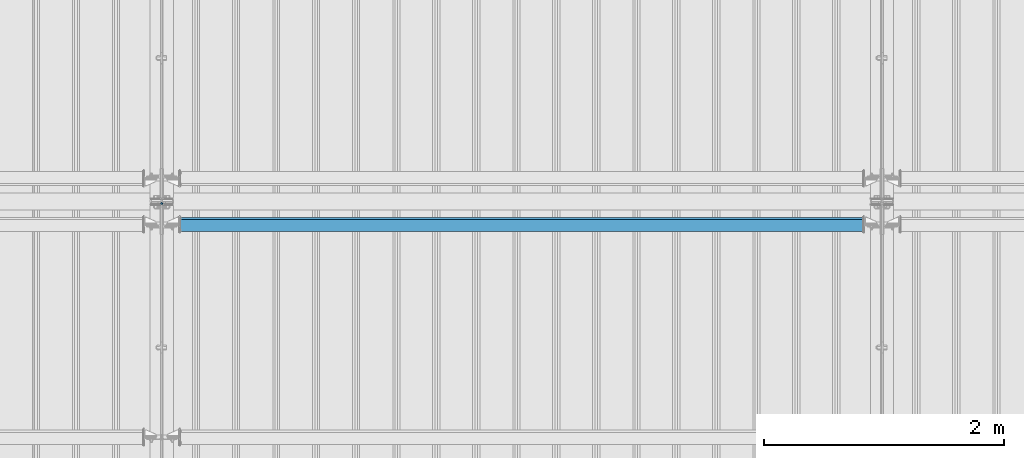
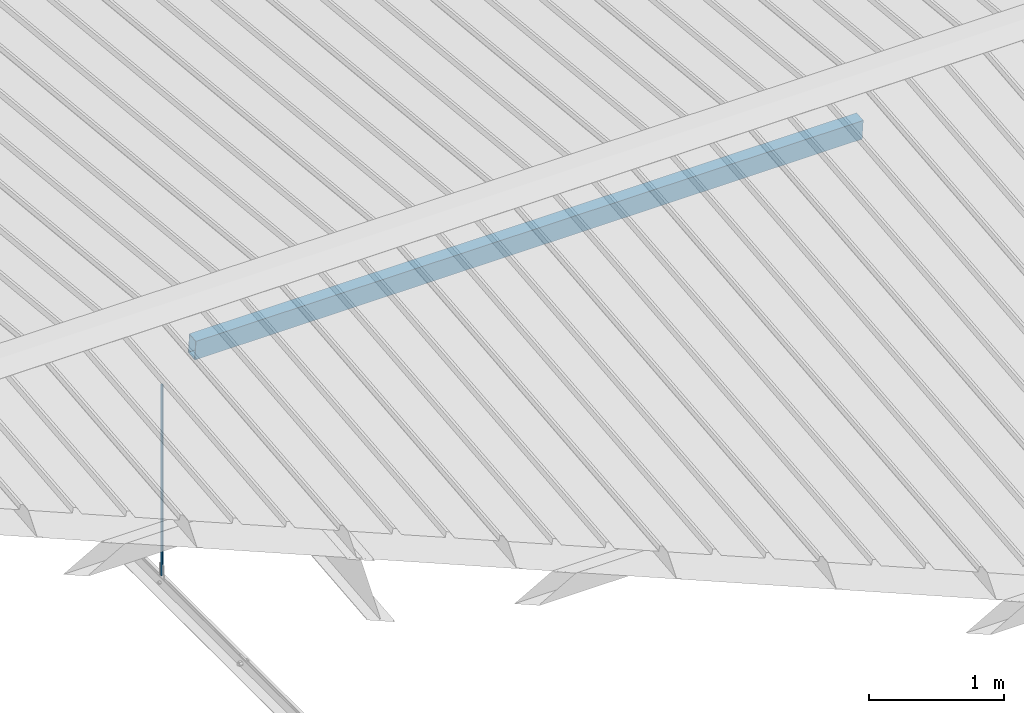
# One storey, part 257 of 709: 2 beams, 2 elements without a shape of their own.
"""IFC4 building model written with IfcOpenShell, lengths in millimetres."""

import ifcopenshell
import ifcopenshell.guid

model = None  # the IFC model being written
_history = None  # IfcOwnerHistory: only IFC2X3 demands one
_inside = {}  # id of a spatial element -> (the spatial element, [elements in it])
_under = {}  # id of a project, library or spatial element -> (it, [spatial elements below it])
_declared = {}  # id of a project -> (the project, [libraries it declares])
_typed = {}  # id of a type object -> (the type object, [elements of that type])
_made_of = {}  # id of a material, layer set ... -> (it, [elements and type objects made of it])


def new_model(schema):
    """Start an empty IFC model of exactly this schema.

    Asked for "IFC4X3", IfcOpenShell would pick the latest addendum, in which some entities
    have other attributes; the version numbers below select the first issue.
    IFC2X3 requires an IfcOwnerHistory on every rooted entity: one is made here for all.
    """
    global model, _history
    if schema == "IFC4X3":
        model = ifcopenshell.file(schema_version=(4, 3, 0, 0))
    else:
        model = ifcopenshell.file(schema=schema)
    _inside.clear()
    _under.clear()
    _declared.clear()
    _typed.clear()
    _made_of.clear()
    _history = None
    if model.schema == "IFC2X3":
        org = make("IfcOrganization", Name="unknown")
        user = make(
            "IfcPersonAndOrganization",
            ThePerson=make("IfcPerson", FamilyName="unknown"),
            TheOrganization=org,
        )
        app = make(
            "IfcApplication",
            ApplicationDeveloper=org,
            Version="unknown",
            ApplicationFullName="unknown",
            ApplicationIdentifier="unknown",
        )
        _history = make(
            "IfcOwnerHistory",
            OwningUser=user,
            OwningApplication=app,
            ChangeAction="ADDED",
            CreationDate=0,
        )
    return model


def make(cls, **values):
    """One entity of the class cls with the attributes given. An attribute that is None is left unset."""
    return model.create_entity(
        cls, **{name: value for name, value in values.items() if value is not None}
    )


def rooted(cls, **values):
    """An entity with a GlobalId (a new one), such as an element, a storey or a relation."""
    return make(cls, GlobalId=ifcopenshell.guid.new(), OwnerHistory=_history, **values)


def si_unit(unit_type, name, prefix=None):
    """IfcSIUnit, for example si_unit("LENGTHUNIT", "METRE", prefix="MILLI")."""
    return make("IfcSIUnit", UnitType=unit_type, Prefix=prefix, Name=name)


def assignment(units):
    """IfcUnitAssignment: the units of a project."""
    return None if units is None else make("IfcUnitAssignment", Units=units)


def point(xyz):
    """IfcCartesianPoint."""
    return None if xyz is None else make("IfcCartesianPoint", Coordinates=xyz)


def direction(xyz):
    """IfcDirection."""
    return None if xyz is None else make("IfcDirection", DirectionRatios=xyz)


def frame(location, z_axis=None, x_axis=None):
    """IfcAxis2Placement3D, a coordinate frame: its origin and axes. An axis left out is left unset."""
    return make(
        "IfcAxis2Placement3D",
        Location=point(location),
        Axis=direction(z_axis),
        RefDirection=direction(x_axis),
    )


def origin_with_axes():
    """The frame at (0, 0, 0) with the z axis (0, 0, 1) and the x axis (1, 0, 0) written out."""
    return frame((0.0, 0.0, 0.0), z_axis=(0.0, 0.0, 1.0), x_axis=(1.0, 0.0, 0.0))


def place(relative_to, where):
    """IfcLocalPlacement: puts the frame where relative to a parent placement (None: the world)."""
    return make(
        "IfcLocalPlacement", PlacementRelTo=relative_to, RelativePlacement=where
    )


def context(
    kind, dimensions, precision=None, world=None, true_north=None, identifier=None
):
    """IfcGeometricRepresentationContext, for example the 3D "Model" context."""
    return make(
        "IfcGeometricRepresentationContext",
        ContextIdentifier=identifier,
        ContextType=kind,
        CoordinateSpaceDimension=dimensions,
        Precision=precision,
        WorldCoordinateSystem=world,
        TrueNorth=true_north,
    )


def subcontext(parent, identifier, kind, view, scale=None):
    """IfcGeometricRepresentationSubContext, for example "Body" below "Model"."""
    return make(
        "IfcGeometricRepresentationSubContext",
        ContextIdentifier=identifier,
        ContextType=kind,
        ParentContext=parent,
        TargetScale=scale,
        TargetView=view,
    )


def project(units=None, contexts=None):
    """IfcProject with its units and contexts."""
    return rooted(
        "IfcProject",
        Name="project",
        RepresentationContexts=contexts,
        UnitsInContext=assignment(units),
    )


def spatial(cls, under=None, at=None, **own):
    """A site, building, storey or space (cls), placed at a placement, below another one or the project."""
    s = rooted(cls, ObjectPlacement=at, **own)
    if under is not None:
        _under.setdefault(under.id(), (under, []))[1].append(s)
    return s


def point_list(points):
    """IfcCartesianPointList2D or 3D."""
    cls = (
        "IfcCartesianPointList2D" if len(points[0]) == 2 else "IfcCartesianPointList3D"
    )
    return make(cls, CoordList=points)


def polygons(points, faces, closed=None, point_numbers=None):
    """IfcPolygonalFaceSet: a face is its outer loop, then its inner loops; points numbered from 1."""
    made = []
    for loops in faces:
        if len(loops) == 1:
            made.append(make("IfcIndexedPolygonalFace", CoordIndex=loops[0]))
        else:
            made.append(
                make(
                    "IfcIndexedPolygonalFaceWithVoids",
                    CoordIndex=loops[0],
                    InnerCoordIndices=loops[1:],
                )
            )
    return make(
        "IfcPolygonalFaceSet",
        Coordinates=point_list(points),
        Closed=closed,
        Faces=made,
        PnIndex=point_numbers,
    )


def shape(context_of_items, identifier, shape_type, items):
    """IfcShapeRepresentation: the items that make up one representation, for example the "Body"."""
    return make(
        "IfcShapeRepresentation",
        ContextOfItems=context_of_items,
        RepresentationIdentifier=identifier,
        RepresentationType=shape_type,
        Items=items,
    )


def material(Name=None, Category=None):
    """IfcMaterial."""
    return make("IfcMaterial", Name=Name, Category=Category)


def made_of(thing, what):
    """Note that an element or type object is made of a material, layer set ...; save() writes the relation."""
    if what is not None:
        _made_of.setdefault(what.id(), (what, []))[1].append(thing)
    return thing


def element(
    cls,
    number,
    at=None,
    inside=None,
    cuts=None,
    type_object=None,
    material=None,
    context=None,
    identifier="Body",
    shape_type=None,
    held_by="IfcProductDefinitionShape",
    body=None,
    shapes=None,
    **own,
):
    """One element of the class cls, such as IfcWall. Its Tag is "e" and its number.

    at: its placement. inside: the storey or other place that contains it. cuts: it is an
    opening in that element (IfcRelVoidsElement). A single representation is given by context,
    identifier, shape_type and body (its items); several are given by shapes. held_by: the class
    of the entity that holds the representations. save() writes the other relations.
    """
    e = rooted(cls, Tag="e%d" % number, ObjectPlacement=at, **own)
    if body is not None:
        shapes = [shape(context, identifier, shape_type, body)]
    if shapes is not None:
        e.Representation = make(held_by, Representations=shapes)
    if inside is not None:
        _inside.setdefault(inside.id(), (inside, []))[1].append(e)
    if cuts is not None:
        rooted(
            "IfcRelVoidsElement", RelatingBuildingElement=cuts, RelatedOpeningElement=e
        )
    if type_object is not None:
        _typed.setdefault(type_object.id(), (type_object, []))[1].append(e)
    return made_of(e, material)


def aggregate(whole, parts):
    """IfcRelAggregates: a whole, such as a stair, and the parts it consists of."""
    return rooted("IfcRelAggregates", RelatingObject=whole, RelatedObjects=parts)


def save(model, path):
    """Write the relations noted so far, then the file.

    IfcRelAggregates (storeys below a building ...), IfcRelContainedInSpatialStructure (elements
    in a storey), IfcRelDefinesByType, IfcRelAssociatesMaterial and IfcRelDeclares: one each for
    every whole, place, type object, material and project.
    """
    for whole, parts in _under.values():
        aggregate(whole, parts)
    for where, things in _inside.values():
        rooted(
            "IfcRelContainedInSpatialStructure",
            RelatedElements=things,
            RelatingStructure=where,
        )
    for kind, things in _typed.values():
        rooted("IfcRelDefinesByType", RelatedObjects=things, RelatingType=kind)
    for what, things in _made_of.values():
        rooted("IfcRelAssociatesMaterial", RelatedObjects=things, RelatingMaterial=what)
    for by, libraries in _declared.values():
        rooted("IfcRelDeclares", RelatingContext=by, RelatedDefinitions=libraries)
    model.write(path)


model = new_model("IFC4")

# Units and contexts
model_context = context("Model", 3, precision=0.2, world=origin_with_axes(), true_north=direction((0.0, 1.0)))
body_context = subcontext(model_context, "Body", "Model", "MODEL_VIEW")
ifc_project = project(units=[si_unit("LENGTHUNIT", "METRE", prefix="MILLI"), si_unit("AREAUNIT", "SQUARE_METRE"), si_unit("VOLUMEUNIT", "CUBIC_METRE"), si_unit("MASSUNIT", "GRAM", prefix="KILO"), si_unit("TIMEUNIT", "SECOND"), si_unit("PLANEANGLEUNIT", "RADIAN"), si_unit("SOLIDANGLEUNIT", "STERADIAN"), si_unit("THERMODYNAMICTEMPERATUREUNIT", "DEGREE_CELSIUS"), si_unit("LUMINOUSINTENSITYUNIT", "LUMEN")], contexts=[model_context])

# Site, building, storey
site_placement = place(None, origin_with_axes())
site = spatial("IfcSite", under=ifc_project, at=site_placement, CompositionType="ELEMENT")
building_placement = place(site_placement, origin_with_axes())
building = spatial("IfcBuilding", under=site, at=building_placement, Name="Undefined", CompositionType="ELEMENT")
storey_placement = place(building_placement, origin_with_axes())
storey = spatial("IfcBuildingStorey", under=building, at=storey_placement, Name="Undefined", CompositionType="ELEMENT", Elevation=0.0)

# Assembly, beam
assembly_1_placement = place(storey_placement, frame((16000.0, 10985.0, 8155.10002), z_axis=(0.0, -1.0, 0.0), x_axis=(0.0, 0.0, -1.0)))
assembly_1 = element("IfcElementAssembly", 1, at=assembly_1_placement, inside=storey)
ifc_material_1 = material(Name="C355-5", Category="STEEL")
beam_1_placement = place(assembly_1_placement, origin_with_axes())
beam_1 = element("IfcBeam", 2, at=beam_1_placement, material=ifc_material_1, ObjectType="437", context=body_context, shape_type="Tessellation", body=[
    polygons([(326.36285, 0.0, 10.0), (326.36285, -2.58819, 9.65926), (2045.1, -2.58819, 9.65926), (2045.1, 0.0, 10.0), (326.36285, -5.0, 8.66025), (2045.1, -5.0, 8.66025), (326.36285, -7.07107, 7.07107), (2045.1, -7.07107, 7.07107), (326.36285, -8.66025, 5.0), (2045.1, -8.66025, 5.0), (326.36285, -9.65926, 2.58819), (2045.1, -9.65926, 2.58819), (326.36285, -10.0, 0.0), (2045.1, -10.0, 0.0), (326.36285, -9.65926, -2.58819), (2045.1, -9.65926, -2.58819), (326.36285, -8.66025, -5.0), (2045.1, -8.66025, -5.0), (326.36285, -7.07107, -7.07107), (2045.1, -7.07107, -7.07107), (326.36285, -5.0, -8.66025), (2045.1, -5.0, -8.66025), (326.36285, -2.58819, -9.65926), (2045.1, -2.58819, -9.65926), (326.36285, 0.0, -10.0), (2045.1, 0.0, -10.0), (326.36285, 2.58819, -9.65926), (2045.1, 2.58819, -9.65926), (326.36285, 5.0, -8.66025), (2045.1, 5.0, -8.66025), (326.36285, 7.07107, -7.07107), (2045.1, 7.07107, -7.07107), (326.36285, 8.66025, -5.0), (2045.1, 8.66025, -5.0), (326.36285, 9.65926, -2.58819), (2045.1, 9.65926, -2.58819), (326.36285, 10.0, 0.0), (2045.1, 10.0, 0.0), (326.36285, 9.65926, 2.58819), (2045.1, 9.65926, 2.58819), (326.36285, 8.66025, 5.0), (2045.1, 8.66025, 5.0), (326.36285, 7.07107, 7.07107), (2045.1, 7.07107, 7.07107), (326.36285, 5.0, 8.66025), (2045.1, 5.0, 8.66025), (326.36285, 2.58819, 9.65926), (2045.1, 2.58819, 9.65926)], [[[1, 2, 3, 4]], [[2, 5, 6, 3]], [[5, 7, 8, 6]], [[7, 9, 10, 8]], [[9, 11, 12, 10]], [[11, 13, 14, 12]], [[13, 15, 16, 14]], [[15, 17, 18, 16]], [[17, 19, 20, 18]], [[19, 21, 22, 20]], [[21, 23, 24, 22]], [[23, 25, 26, 24]], [[25, 27, 28, 26]], [[27, 29, 30, 28]], [[29, 31, 32, 30]], [[31, 33, 34, 32]], [[33, 35, 36, 34]], [[35, 37, 38, 36]], [[37, 39, 40, 38]], [[39, 41, 42, 40]], [[41, 43, 44, 42]], [[43, 45, 46, 44]], [[45, 47, 48, 46]], [[47, 1, 4, 48]], [[6, 8, 10, 12, 14, 16, 18, 20, 22, 24, 26, 28, 30, 32, 34, 36, 38, 40, 42, 44, 46, 48, 4, 3]], [[47, 45, 43, 41, 39, 37, 35, 33, 31, 29, 27, 25, 23, 21, 19, 17, 15, 13, 11, 9, 7, 5, 2, 1]]], closed=True),
])
aggregate(assembly_1, [beam_1])

assembly_2_placement = place(storey_placement, frame((16000.0, 10808.95533, 8219.40952), z_axis=(0.0, 0.9950371902, 0.099503719), x_axis=(1.0, 0.0, 0.0)))
assembly_2 = element("IfcElementAssembly", 3, at=assembly_2_placement, inside=storey)
ifc_material_2 = material(Name="C355", Category="STEEL")
beam_2_placement = place(assembly_2_placement, origin_with_axes())
beam_2 = element("IfcBeam", 4, at=beam_2_placement, material=ifc_material_2, ObjectType="580", context=body_context, shape_type="Tessellation", body=[
    polygons([(155.0, -86.0, -46.0), (155.0, -86.0, 46.0), (5845.0, -86.0, 46.0), (5845.0, -86.0, -46.0), (155.0, 86.0, 46.0), (5845.0, 86.0, 46.0), (155.0, 86.0, -46.0), (5845.0, 86.0, -46.0), (155.0, -90.0, -50.0), (155.0, 90.0, -50.0), (5845.0, 90.0, -50.0), (5845.0, -90.0, -50.0), (155.0, 90.0, 50.0), (5845.0, 90.0, 50.0), (155.0, -90.0, 50.0), (5845.0, -90.0, 50.0)], [[[1, 2, 3, 4]], [[2, 5, 6, 3]], [[5, 7, 8, 6]], [[7, 1, 4, 8]], [[9, 10, 11, 12]], [[10, 13, 14, 11]], [[13, 15, 16, 14]], [[15, 9, 12, 16]], [[14, 16, 12, 11], [6, 8, 4, 3]], [[15, 13, 10, 9], [7, 5, 2, 1]]], closed=True),
])
aggregate(assembly_2, [beam_2])

save(model, "model.ifc")
